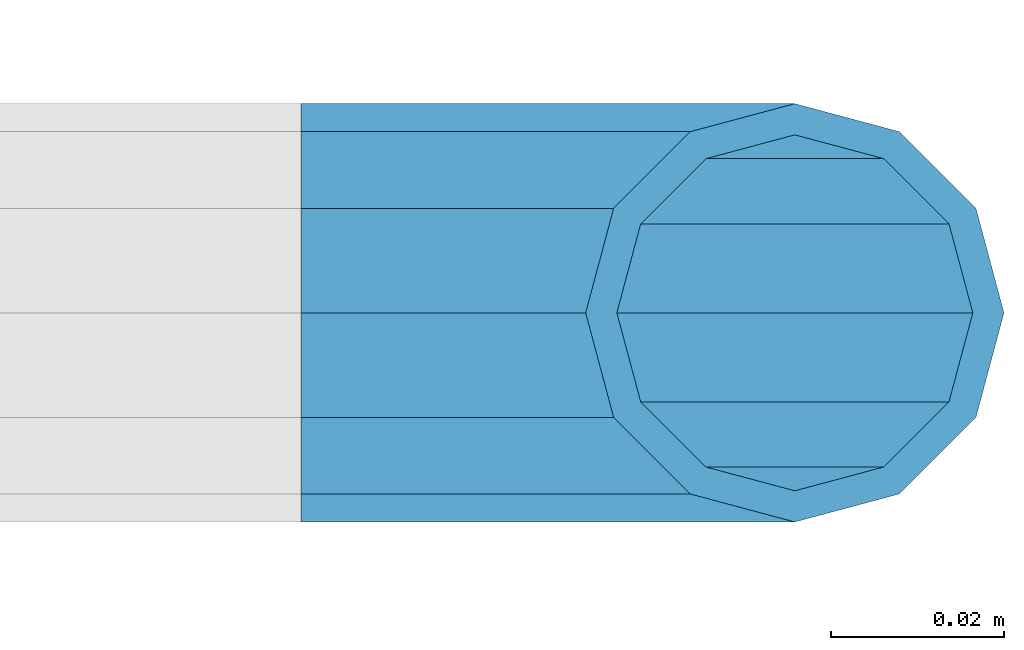
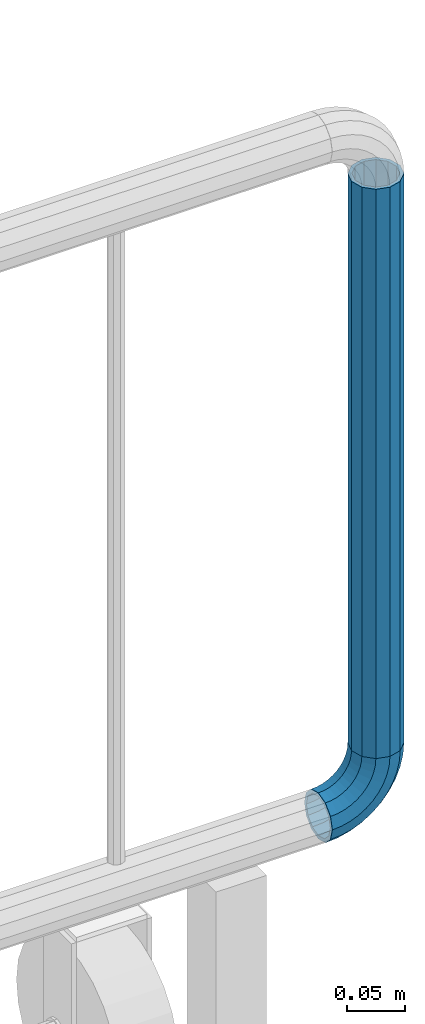
# One storey, part 171 of 240: 1 beam, 1 member.
"""IFC2X3 building model written with IfcOpenShell, lengths in millimetres."""

from ifc_helpers import new_model, si_unit, frame, origin_with_axes, place, context, subcontext, project, spatial, faceted_brep, material, type_object, element, save


model = new_model("IFC2X3")

# Units and contexts
model_context = context("Model", 3, precision=1e-05, world=origin_with_axes())
body_context = subcontext(model_context, "Body", "Model", "MODEL_VIEW")
ifc_project = project(units=[si_unit("LENGTHUNIT", "METRE", prefix="MILLI"), si_unit("AREAUNIT", "SQUARE_METRE"), si_unit("VOLUMEUNIT", "CUBIC_METRE"), si_unit("MASSUNIT", "GRAM", prefix="KILO"), si_unit("TIMEUNIT", "SECOND"), si_unit("PLANEANGLEUNIT", "RADIAN"), si_unit("SOLIDANGLEUNIT", "STERADIAN"), si_unit("THERMODYNAMICTEMPERATUREUNIT", "DEGREE_CELSIUS"), si_unit("LUMINOUSINTENSITYUNIT", "LUMEN")], contexts=[model_context])

# Site, building, storey
site_placement = place(None, origin_with_axes())
site = spatial("IfcSite", under=ifc_project, at=site_placement, CompositionType="ELEMENT")
building_placement = place(site_placement, origin_with_axes())
building = spatial("IfcBuilding", under=site, at=building_placement, Name="Standard", CompositionType="ELEMENT")
storey_placement = place(building_placement, origin_with_axes())
storey = spatial("IfcBuildingStorey", under=building, at=storey_placement, Name="Undefined", CompositionType="ELEMENT", Elevation=0.0)

# Member
ifc_material = material()
member_type = type_object("IfcMemberType", PredefinedType="NOTDEFINED")
member_placement = place(storey_placement, frame((69989.9460172356, 32941.8539999962, 281.650006544463), z_axis=(0.0, -1.0, 0.0), x_axis=(-0.707106781186548, 0.0, -0.707106781186548)))
element("IfcMember", 1, at=member_placement, inside=storey, type_object=member_type, material=ifc_material, context=body_context, shape_type="Brep", body=[
    faceted_brep([(17.0766287656515, -17.0766287656661, 0.0), (14.7887943220485, -14.788794322063, -12.0749999999971), (19.0945697419447, -11.1113146999778, -12.0749999999971), (20.9963409898191, -13.7288782624237, 0.0), (8.53831438282214, -8.53831438283669, -20.9145135013969), (13.8988340683864, -3.95999805534666, -20.9145135013969), (-7.27595761418343e-12, -7.27595761418343e-12, -24.1500000000015), (6.80132714695355, 5.80888215173036, -24.1500000000015), (-8.53831438283669, 8.53831438282214, -20.9145135013969), (-0.296179774479242, 15.5777623588074, -20.9145135013969), (-14.788794322063, 14.7887943220485, -12.0749999999971), (-5.49191544803034, 22.7290790034458, -12.0749999999971), (-17.0766287656588, 17.0766287656443, 0.0), (-7.39368669591204, 25.3466425658844, 0.0), (-14.788794322063, 14.7887943220485, 12.0749999999971), (-5.49191544803034, 22.7290790034458, 12.0749999999971), (-8.53831438283669, 8.53831438282214, 20.9145135013969), (-0.296179774479242, 15.5777623588074, 20.9145135013969), (-7.27595761418343e-12, -7.27595761418343e-12, 24.1500000000015), (6.80132714695355, 5.80888215173036, 24.1500000000015), (8.53831438282214, -8.53831438283669, 20.9145135013969), (13.8988340683864, -3.95999805534666, 20.9145135013969), (14.7887943220485, -14.788794322063, 12.0749999999971), (19.0945697419447, -11.1113146999778, 12.0749999999971), (14.5310443533745, -14.531044353389, 0.0), (12.5842535535412, -12.5842535535558, 10.2750000000015), (17.2620366843112, -8.58904933077429, 10.2750000000015), (18.8803140815653, -10.8164170826713, 0.0), (7.26552217668359, -7.26552217669814, 17.7968220477705), (12.8408206142631, -2.50376746547408, 17.7968220477705), (-7.27595761418343e-12, -7.27595761418343e-12, 20.5500000000029), (6.80132714695355, 5.80888215173036, 20.5500000000029), (-7.26552217669814, 7.26552217668359, 17.7968220477705), (0.761833679658594, 14.1215317689348, 17.7968220477705), (-12.5842535535558, 12.5842535535412, 10.2750000000015), (-3.65938239038951, 20.2068136342496, 10.2750000000015), (-14.531044353389, 14.5310443533745, 0.0), (-5.27765978765092, 22.4341813861392, 0.0), (-12.5842535535558, 12.5842535535412, -10.2750000000015), (-3.65938239038951, 20.2068136342496, -10.2750000000015), (-7.26552217669814, 7.26552217668359, -17.7968220477705), (0.761833679658594, 14.1215317689348, -17.7968220477705), (-7.27595761418343e-12, -7.27595761418343e-12, -20.5500000000029), (6.80132714695355, 5.80888215173036, -20.5500000000029), (7.26552217668359, -7.26552217669814, -17.7968220477705), (12.8408206142631, -2.50376746547408, -17.7968220477705), (12.5842535535412, -12.5842535535558, -10.2750000000015), (17.2620366843112, -8.58904933077429, -10.2750000000015), (23.922618478784, -8.15268262886093, -12.0749999999971), (25.3914986111849, -11.035522208047, 0.0), (19.9095633268225, -0.276618428477377, -20.9145135013969), (14.427628042482, 10.4822853510996, -24.1500000000015), (8.94569275811955, 21.2411891306692, -20.9145135013969), (4.93263760617265, 29.1172533310673, -12.0749999999971), (3.46375747377169, 32.0000929102534, 0.0), (4.93263760617265, 29.1172533310673, 12.0749999999971), (8.94569275811955, 21.2411891306692, 20.9145135013969), (14.427628042482, 10.4822853510996, 24.1500000000015), (19.9095633268225, -0.276618428477377, 20.9145135013969), (23.922618478784, -8.15268262886093, 12.0749999999971), (22.5072161777207, -5.37479920328769, 10.2750000000015), (23.7571328121194, -7.82789872097055, 0.0), (19.092380427297, 1.32719331506087, 17.7968220477705), (14.427628042482, 10.4822853510996, 20.5500000000029), (9.76287565764505, 19.637377387131, 17.7968220477705), (6.34803990724322, 26.3393699054868, 10.2750000000015), (5.09812327282998, 28.7924694231697, 0.0), (6.34803990724322, 26.3393699054868, -10.2750000000015), (9.76287565764505, 19.637377387131, -17.7968220477705), (14.427628042482, 10.4822853510996, -20.5500000000029), (19.092380427297, 1.32719331506087, -17.7968220477705), (22.5072161777207, -5.37479920328769, -10.2750000000015), (29.1540579492721, -5.98574944946449, -12.0749999999971), (30.153878262412, -9.06287996734318, 0.0), (26.4224980553408, 2.42112746692146, -20.9145135013969), (22.6911178482551, 13.9051349011861, -24.1500000000015), (18.9597376411839, 25.3891423354507, -20.9145135013969), (16.2281777472454, 33.7960192518294, -12.0749999999971), (15.2283574340981, 36.8731497697154, 0.0), (16.2281777472454, 33.7960192518294, 12.0749999999971), (18.9597376411839, 25.3891423354507, 20.9145135013969), (22.6911178482551, 13.9051349011861, 24.1500000000015), (26.4224980553408, 2.42112746692146, 20.9145135013969), (29.1540579492721, -5.98574944946449, 12.0749999999971), (28.1906383068854, -3.02064867669833, 10.2750000000015), (29.0414170826625, -5.63907650867623, 0.0), (25.8662674654624, 4.1330291962513, 17.7968220477705), (22.6911178482551, 13.9051349011861, 20.5500000000029), (19.515968231055, 23.6772406061136, 17.7968220477705), (17.1915973896321, 30.8309184790633, 10.2750000000015), (16.3408186138549, 33.4493463110557, 0.0), (17.1915973896321, 30.8309184790633, -10.2750000000015), (19.515968231055, 23.6772406061136, -17.7968220477705), (22.6911178482551, 13.9051349011861, -20.5500000000029), (25.8662674654624, 4.1330291962513, -17.7968220477705), (28.1906383068854, -3.02064867669833, -10.2750000000015), (34.6600727515033, -4.6638722482603, -12.0749999999971), (35.1662143510621, -7.85952453908976, 0.0), (33.277268185695, 4.06681217360165, -20.9145135013969), (31.3883220203425, 15.9931488862931, -24.1500000000015), (29.4993758549681, 27.9194855989626, -20.9145135013969), (28.116571289167, 36.6501700208319, -12.0749999999971), (27.6104296896156, 39.845822311654, 0.0), (28.116571289167, 36.6501700208319, 12.0749999999971), (29.4993758549681, 27.9194855989626, 20.9145135013969), (31.3883220203425, 15.9931488862931, 24.1500000000015), (33.277268185695, 4.06681217360165, 20.9145135013969), (34.6600727515033, -4.6638722482603, 12.0749999999971), (34.1723583567946, -1.58456474995182, 10.2750000000015), (34.6030502769136, -4.30384651295026, 0.0), (32.9956861486207, 5.8446511866714, 17.7968220477705), (31.3883220203425, 15.9931488862931, 20.5500000000029), (29.7809578920424, 26.1416465858929, 17.7968220477705), (28.6042856838831, 33.5708625225161, 10.2750000000015), (28.1735937637641, 36.2901442855145, 0.0), (28.6042856838831, 33.5708625225161, -10.2750000000015), (29.7809578920424, 26.1416465858929, -17.7968220477705), (31.3883220203425, 15.9931488862931, -20.5500000000029), (32.9956861486207, 5.8446511866714, -17.7968220477705), (34.1723583567946, -1.58456474995182, -10.2750000000015), (40.3050865276236, -4.21960002903506, -12.0749999999971), (40.3050865276236, -7.45508652764693, 0.0), (40.3050865276382, 4.61991347236471, -20.9145135013969), (40.3050865276236, 16.6949134723618, -24.1500000000015), (40.3050865276309, 28.7699134723662, -20.9145135013969), (40.3050865276309, 37.6094269737514, -12.0749999999971), (40.3050865276309, 40.8449134723633, 0.0), (40.3050865276309, 37.6094269737514, 12.0749999999971), (40.3050865276309, 28.7699134723662, 20.9145135013969), (40.3050865276236, 16.6949134723618, 24.1500000000015), (40.3050865276382, 4.61991347236471, 20.9145135013969), (40.3050865276236, -4.21960002903506, 12.0749999999971), (40.3050865276309, -1.10190857540874, 10.2750000000015), (40.3050865276309, -3.85508652763383, 0.0), (40.3050865276309, 6.41991347236035, 17.7968220477705), (40.3050865276236, 16.6949134723618, 20.5500000000029), (40.3050865276236, 26.969913472356, 17.7968220477705), (40.3050865276309, 34.4917355201324, 10.2750000000015), (40.3050865276309, 37.2449134723574, 0.0), (40.3050865276309, 34.4917355201324, -10.2750000000015), (40.3050865276236, 26.969913472356, -17.7968220477705), (40.3050865276236, 16.6949134723618, -20.5500000000029), (40.3050865276309, 6.41991347236035, -17.7968220477705), (40.3050865276309, -1.10190857540874, -10.2750000000015), (45.9501003037585, -4.6638722482603, -12.0749999999971), (45.443958704207, -7.85952453908249, 0.0), (47.3329048695668, 4.06681217360165, -20.9145135013969), (49.2218510349267, 15.9931488862858, -24.1500000000015), (51.1107972002865, 27.9194855989699, -20.9145135013969), (52.4936017660948, 36.6501700208319, -12.0749999999971), (52.9997433656463, 39.845822311654, 0.0), (52.4936017660948, 36.6501700208319, 12.0749999999971), (51.1107972002865, 27.9194855989699, 20.9145135013969), (49.2218510349267, 15.9931488862858, 24.1500000000015), (47.3329048695668, 4.06681217360165, 20.9145135013969), (45.9501003037585, -4.6638722482603, 12.0749999999971), (46.4378146984673, -1.58456474993727, 10.2750000000015), (46.007122778341, -4.30384651294298, 0.0), (47.6144869066411, 5.8446511866714, 17.7968220477705), (49.2218510349267, 15.9931488862858, 20.5500000000029), (50.8292151632122, 26.1416465859002, 17.7968220477705), (52.0058873713788, 33.5708625225161, 10.2750000000015), (52.4365792914905, 36.2901442855073, 0.0), (52.0058873713788, 33.5708625225161, -10.2750000000015), (50.8292151632122, 26.1416465859002, -17.7968220477705), (49.2218510349267, 15.9931488862858, -20.5500000000029), (47.6144869066411, 5.8446511866714, -17.7968220477705), (46.4378146984673, -1.58456474993727, -10.2750000000015), (51.4561151059825, -5.98574944945722, -12.0749999999971), (50.4562947928498, -9.06287996734318, 0.0), (54.187674999921, 2.42112746692146, -20.9145135013969), (57.9190552069995, 13.9051349011788, -24.1500000000015), (61.6504354140779, 25.3891423354507, -20.9145135013969), (64.3819953080165, 33.7960192518294, -12.0749999999971), (65.3818156211564, 36.8731497697081, 0.0), (64.3819953080165, 33.7960192518294, 12.0749999999971), (61.6504354140779, 25.3891423354507, 20.9145135013969), (57.9190552069995, 13.9051349011788, 24.1500000000015), (54.187674999921, 2.42112746692146, 20.9145135013969), (51.4561151059825, -5.98574944945722, 12.0749999999971), (52.4195347483765, -3.02064867668378, 10.2750000000015), (51.5687559725993, -5.63907650867623, 0.0), (54.7439055897994, 4.1330291962513, 17.7968220477705), (57.9190552069995, 13.9051349011788, 20.5500000000029), (61.0942048242068, 23.6772406061282, 17.7968220477705), (63.4185756656298, 30.8309184790633, 10.2750000000015), (64.2693544414069, 33.4493463110557, 0.0), (63.4185756656298, 30.8309184790633, -10.2750000000015), (61.0942048242068, 23.6772406061282, -17.7968220477705), (57.9190552069995, 13.9051349011788, -20.5500000000029), (54.7439055897994, 4.1330291962513, -17.7968220477705), (52.4195347483765, -3.02064867668378, -10.2750000000015), (56.6875545764706, -8.15268262886821, -12.0749999999971), (55.2186744440769, -11.035522208047, 0.0), (60.700609728432, -0.276618428470101, -20.9145135013969), (66.1825450127799, 10.4822853510996, -24.1500000000015), (71.6644802971277, 21.2411891306692, -20.9145135013969), (75.6775354490892, 29.1172533310673, -12.0749999999971), (77.1464155814901, 32.0000929102389, 0.0), (75.6775354490892, 29.1172533310673, 12.0749999999971), (71.6644802971277, 21.2411891306692, 20.9145135013969), (66.1825450127799, 10.4822853510996, 24.1500000000015), (60.700609728432, -0.276618428470101, 20.9145135013969), (56.6875545764706, -8.15268262886821, 12.0749999999971), (58.1029568775411, -5.37479920328769, 10.2750000000015), (56.8530402431425, -7.82789872097055, 0.0), (61.5177926279575, 1.32719331506814, 17.7968220477705), (66.1825450127799, 10.4822853510996, 20.5500000000029), (70.8472973976022, 19.637377387131, 17.7968220477705), (74.2621331480259, 26.3393699054795, 10.2750000000015), (75.5120497824319, 28.7924694231697, 0.0), (74.2621331480259, 26.3393699054795, -10.2750000000015), (70.8472973976022, 19.637377387131, -17.7968220477705), (66.1825450127799, 10.4822853510996, -20.5500000000029), (61.5177926279575, 1.32719331506814, -17.7968220477705), (58.1029568775411, -5.37479920328769, -10.2750000000015), (61.5156033133026, -11.1113146999778, -12.0749999999971), (59.6138320654354, -13.7288782624164, 0.0), (66.7113389868682, -3.95999805533938, -20.9145135013969), (73.808845908301, 5.80888215173763, -24.1500000000015), (80.9063528297338, 15.5777623588147, -20.9145135013969), (86.1020885032849, 22.7290790034385, -12.0749999999971), (88.0038597511593, 25.3466425658844, 0.0), (86.1020885032849, 22.7290790034385, 12.0749999999971), (80.9063528297338, 15.5777623588147, 20.9145135013969), (73.808845908301, 5.80888215173763, 24.1500000000015), (66.7113389868682, -3.95999805533938, 20.9145135013969), (61.5156033133026, -11.1113146999778, 12.0749999999971), (63.3481363709434, -8.58904933078156, 10.2750000000015), (61.7298589736965, -10.8164170826713, 0.0), (67.7693524409915, -2.50376746546681, 17.7968220477705), (73.808845908301, 5.80888215173763, 20.5500000000029), (79.8483393756032, 14.1215317689348, 17.7968220477705), (84.2695554456513, 20.2068136342496, 10.2750000000015), (85.8878328429128, 22.4341813861392, 0.0), (84.2695554456513, 20.2068136342496, -10.2750000000015), (79.8483393756032, 14.1215317689348, -17.7968220477705), (73.808845908301, 5.80888215173763, -20.5500000000029), (67.7693524409915, -2.50376746546681, -17.7968220477705), (63.3481363709434, -8.58904933078156, -10.2750000000015), (65.8213787332061, -14.7887943220558, -12.0749999999971), (63.5335442896103, -17.0766287656515, 0.0), (72.0718586724324, -8.53831438282941, -20.9145135013969), (80.6101730552618, 0.0, -24.1500000000015), (89.148487438084, 8.53831438282214, -20.9145135013969), (95.3989673773176, 14.7887943220558, -12.0749999999971), (97.6868018209134, 17.0766287656515, 0.0), (95.3989673773176, 14.7887943220558, 12.0749999999971), (89.148487438084, 8.53831438282214, 20.9145135013969), (80.6101730552618, 0.0, 24.1500000000015), (72.0718586724324, -8.53831438282941, 20.9145135013969), (65.8213787332061, -14.7887943220558, 12.0749999999971), (68.0259195017134, -12.5842535535485, 10.2750000000015), (66.0791287018728, -14.531044353389, 0.0), (73.344650878571, -7.26552217669087, 17.7968220477705), (80.6101730552618, 0.0, 20.5500000000029), (87.8756952319454, 7.26552217668359, 17.7968220477705), (93.194426608803, 12.5842535535412, 10.2750000000015), (95.1412174086436, 14.5310443533817, 0.0), (93.194426608803, 12.5842535535412, -10.2750000000015), (87.8756952319454, 7.26552217668359, -17.7968220477705), (80.6101730552618, 0.0, -20.5500000000029), (73.344650878571, -7.26552217669087, -17.7968220477705), (68.0259195017134, -12.5842535535485, -10.2750000000015)], [[[0, 1, 2, 3]], [[1, 4, 5, 2]], [[4, 6, 7, 5]], [[6, 8, 9, 7]], [[8, 10, 11, 9]], [[10, 12, 13, 11]], [[12, 14, 15, 13]], [[14, 16, 17, 15]], [[16, 18, 19, 17]], [[18, 20, 21, 19]], [[20, 22, 23, 21]], [[22, 0, 3, 23]], [[24, 25, 26, 27]], [[25, 28, 29, 26]], [[28, 30, 31, 29]], [[30, 32, 33, 31]], [[32, 34, 35, 33]], [[34, 36, 37, 35]], [[36, 38, 39, 37]], [[38, 40, 41, 39]], [[40, 42, 43, 41]], [[42, 44, 45, 43]], [[44, 46, 47, 45]], [[46, 24, 27, 47]], [[22, 20, 18, 16, 14, 12, 10, 8, 6, 4, 1, 0], [46, 44, 42, 40, 38, 36, 34, 32, 30, 28, 25, 24]], [[3, 2, 48, 49]], [[2, 5, 50, 48]], [[5, 7, 51, 50]], [[7, 9, 52, 51]], [[9, 11, 53, 52]], [[11, 13, 54, 53]], [[13, 15, 55, 54]], [[15, 17, 56, 55]], [[17, 19, 57, 56]], [[19, 21, 58, 57]], [[21, 23, 59, 58]], [[23, 3, 49, 59]], [[27, 26, 60, 61]], [[26, 29, 62, 60]], [[29, 31, 63, 62]], [[31, 33, 64, 63]], [[33, 35, 65, 64]], [[35, 37, 66, 65]], [[37, 39, 67, 66]], [[39, 41, 68, 67]], [[41, 43, 69, 68]], [[43, 45, 70, 69]], [[45, 47, 71, 70]], [[47, 27, 61, 71]], [[49, 48, 72, 73]], [[48, 50, 74, 72]], [[50, 51, 75, 74]], [[51, 52, 76, 75]], [[52, 53, 77, 76]], [[53, 54, 78, 77]], [[54, 55, 79, 78]], [[55, 56, 80, 79]], [[56, 57, 81, 80]], [[57, 58, 82, 81]], [[58, 59, 83, 82]], [[59, 49, 73, 83]], [[61, 60, 84, 85]], [[60, 62, 86, 84]], [[62, 63, 87, 86]], [[63, 64, 88, 87]], [[64, 65, 89, 88]], [[65, 66, 90, 89]], [[66, 67, 91, 90]], [[67, 68, 92, 91]], [[68, 69, 93, 92]], [[69, 70, 94, 93]], [[70, 71, 95, 94]], [[71, 61, 85, 95]], [[73, 72, 96, 97]], [[72, 74, 98, 96]], [[74, 75, 99, 98]], [[75, 76, 100, 99]], [[76, 77, 101, 100]], [[77, 78, 102, 101]], [[78, 79, 103, 102]], [[79, 80, 104, 103]], [[80, 81, 105, 104]], [[81, 82, 106, 105]], [[82, 83, 107, 106]], [[83, 73, 97, 107]], [[85, 84, 108, 109]], [[84, 86, 110, 108]], [[86, 87, 111, 110]], [[87, 88, 112, 111]], [[88, 89, 113, 112]], [[89, 90, 114, 113]], [[90, 91, 115, 114]], [[91, 92, 116, 115]], [[92, 93, 117, 116]], [[93, 94, 118, 117]], [[94, 95, 119, 118]], [[95, 85, 109, 119]], [[97, 96, 120, 121]], [[96, 98, 122, 120]], [[98, 99, 123, 122]], [[99, 100, 124, 123]], [[100, 101, 125, 124]], [[101, 102, 126, 125]], [[102, 103, 127, 126]], [[103, 104, 128, 127]], [[104, 105, 129, 128]], [[105, 106, 130, 129]], [[106, 107, 131, 130]], [[107, 97, 121, 131]], [[109, 108, 132, 133]], [[108, 110, 134, 132]], [[110, 111, 135, 134]], [[111, 112, 136, 135]], [[112, 113, 137, 136]], [[113, 114, 138, 137]], [[114, 115, 139, 138]], [[115, 116, 140, 139]], [[116, 117, 141, 140]], [[117, 118, 142, 141]], [[118, 119, 143, 142]], [[119, 109, 133, 143]], [[121, 120, 144, 145]], [[120, 122, 146, 144]], [[122, 123, 147, 146]], [[123, 124, 148, 147]], [[124, 125, 149, 148]], [[125, 126, 150, 149]], [[126, 127, 151, 150]], [[127, 128, 152, 151]], [[128, 129, 153, 152]], [[129, 130, 154, 153]], [[130, 131, 155, 154]], [[131, 121, 145, 155]], [[133, 132, 156, 157]], [[132, 134, 158, 156]], [[134, 135, 159, 158]], [[135, 136, 160, 159]], [[136, 137, 161, 160]], [[137, 138, 162, 161]], [[138, 139, 163, 162]], [[139, 140, 164, 163]], [[140, 141, 165, 164]], [[141, 142, 166, 165]], [[142, 143, 167, 166]], [[143, 133, 157, 167]], [[145, 144, 168, 169]], [[144, 146, 170, 168]], [[146, 147, 171, 170]], [[147, 148, 172, 171]], [[148, 149, 173, 172]], [[149, 150, 174, 173]], [[150, 151, 175, 174]], [[151, 152, 176, 175]], [[152, 153, 177, 176]], [[153, 154, 178, 177]], [[154, 155, 179, 178]], [[155, 145, 169, 179]], [[157, 156, 180, 181]], [[156, 158, 182, 180]], [[158, 159, 183, 182]], [[159, 160, 184, 183]], [[160, 161, 185, 184]], [[161, 162, 186, 185]], [[162, 163, 187, 186]], [[163, 164, 188, 187]], [[164, 165, 189, 188]], [[165, 166, 190, 189]], [[166, 167, 191, 190]], [[167, 157, 181, 191]], [[169, 168, 192, 193]], [[168, 170, 194, 192]], [[170, 171, 195, 194]], [[171, 172, 196, 195]], [[172, 173, 197, 196]], [[173, 174, 198, 197]], [[174, 175, 199, 198]], [[175, 176, 200, 199]], [[176, 177, 201, 200]], [[177, 178, 202, 201]], [[178, 179, 203, 202]], [[179, 169, 193, 203]], [[181, 180, 204, 205]], [[180, 182, 206, 204]], [[182, 183, 207, 206]], [[183, 184, 208, 207]], [[184, 185, 209, 208]], [[185, 186, 210, 209]], [[186, 187, 211, 210]], [[187, 188, 212, 211]], [[188, 189, 213, 212]], [[189, 190, 214, 213]], [[190, 191, 215, 214]], [[191, 181, 205, 215]], [[193, 192, 216, 217]], [[192, 194, 218, 216]], [[194, 195, 219, 218]], [[195, 196, 220, 219]], [[196, 197, 221, 220]], [[197, 198, 222, 221]], [[198, 199, 223, 222]], [[199, 200, 224, 223]], [[200, 201, 225, 224]], [[201, 202, 226, 225]], [[202, 203, 227, 226]], [[203, 193, 217, 227]], [[205, 204, 228, 229]], [[204, 206, 230, 228]], [[206, 207, 231, 230]], [[207, 208, 232, 231]], [[208, 209, 233, 232]], [[209, 210, 234, 233]], [[210, 211, 235, 234]], [[211, 212, 236, 235]], [[212, 213, 237, 236]], [[213, 214, 238, 237]], [[214, 215, 239, 238]], [[215, 205, 229, 239]], [[217, 216, 240, 241]], [[216, 218, 242, 240]], [[218, 219, 243, 242]], [[219, 220, 244, 243]], [[220, 221, 245, 244]], [[221, 222, 246, 245]], [[222, 223, 247, 246]], [[223, 224, 248, 247]], [[224, 225, 249, 248]], [[225, 226, 250, 249]], [[226, 227, 251, 250]], [[227, 217, 241, 251]], [[229, 228, 252, 253]], [[228, 230, 254, 252]], [[230, 231, 255, 254]], [[231, 232, 256, 255]], [[232, 233, 257, 256]], [[233, 234, 258, 257]], [[234, 235, 259, 258]], [[235, 236, 260, 259]], [[236, 237, 261, 260]], [[237, 238, 262, 261]], [[238, 239, 263, 262]], [[239, 229, 253, 263]], [[242, 243, 244, 245, 246, 247, 248, 249, 250, 251, 241, 240], [254, 255, 256, 257, 258, 259, 260, 261, 262, 263, 253, 252]]]),
])

# Beam
beam_type = type_object("IfcBeamType", PredefinedType="NOTDEFINED")
beam_placement = place(storey_placement, frame((69989.9460172356, 32941.8539999962, 878.350006544462), z_axis=(1.0, 0.0, 0.0), x_axis=(0.0, 0.0, -1.0)))
element("IfcBeam", 2, at=beam_placement, inside=storey, type_object=beam_type, material=ifc_material, context=body_context, shape_type="Brep", body=[
    faceted_brep([(0.0, -20.5500000000029, 0.0), (0.0, -17.7968220477705, 10.2749999999942), (596.700000000001, -17.7968220477705, 10.2749999999942), (596.700000000001, -20.5500000000029, 0.0), (0.0, -10.2750000000015, 17.7968220477633), (596.700000000001, -10.2750000000015, 17.7968220477633), (-7.27595761418343e-12, -7.27595761418343e-12, 20.5500000000029), (596.700000000001, 0.0, 20.5500000000029), (0.0, 10.2750000000015, 17.7968220477633), (596.700000000001, 10.2750000000015, 17.7968220477633), (0.0, 17.7968220477705, 10.2749999999942), (596.700000000001, 17.7968220477705, 10.2749999999942), (0.0, 20.5500000000029, 0.0), (596.700000000001, 20.5500000000029, 0.0), (0.0, 17.7968220477705, -10.2749999999942), (596.700000000001, 17.7968220477705, -10.2749999999942), (0.0, 10.2750000000015, -17.7968220477633), (596.700000000001, 10.2750000000015, -17.7968220477633), (-7.27595761418343e-12, -7.27595761418343e-12, -20.5500000000029), (596.700000000001, 0.0, -20.5500000000029), (0.0, -10.2750000000015, -17.7968220477633), (596.700000000001, -10.2750000000015, -17.7968220477633), (0.0, -17.7968220477705, -10.2749999999942), (596.700000000001, -17.7968220477705, -10.2749999999942), (0.0, -24.1500000000015, 0.0), (0.0, -20.9145135013969, -12.0749999999971), (596.700000000001, -20.9145135013969, -12.0749999999971), (596.700000000001, -24.1500000000015, 0.0), (0.0, -12.0749999999971, -20.9145135013969), (596.700000000001, -12.0749999999971, -20.9145135013969), (-7.27595761418343e-12, -7.27595761418343e-12, -24.1500000000015), (596.700000000001, 0.0, -24.1499999999942), (0.0, 12.0749999999971, -20.9145135013969), (596.700000000001, 12.0749999999971, -20.9145135013969), (0.0, 20.9145135013969, -12.0749999999971), (596.700000000001, 20.9145135013969, -12.0749999999971), (0.0, 24.1500000000015, 0.0), (596.700000000001, 24.1500000000015, 0.0), (0.0, 20.9145135013969, 12.0749999999971), (596.700000000001, 20.9145135013969, 12.0749999999971), (0.0, 12.0749999999971, 20.9145135013969), (596.700000000001, 12.0749999999971, 20.9145135013969), (-7.27595761418343e-12, -7.27595761418343e-12, 24.1500000000015), (596.700000000001, 0.0, 24.1499999999942), (0.0, -12.0749999999971, 20.9145135013969), (596.700000000001, -12.0749999999971, 20.9145135013969), (0.0, -20.9145135013969, 12.0749999999971), (596.700000000001, -20.9145135013969, 12.0749999999971)], [[[0, 1, 2, 3]], [[1, 4, 5, 2]], [[4, 6, 7, 5]], [[6, 8, 9, 7]], [[8, 10, 11, 9]], [[10, 12, 13, 11]], [[12, 14, 15, 13]], [[14, 16, 17, 15]], [[16, 18, 19, 17]], [[18, 20, 21, 19]], [[20, 22, 23, 21]], [[22, 0, 3, 23]], [[24, 25, 26, 27]], [[25, 28, 29, 26]], [[28, 30, 31, 29]], [[30, 32, 33, 31]], [[32, 34, 35, 33]], [[34, 36, 37, 35]], [[36, 38, 39, 37]], [[38, 40, 41, 39]], [[40, 42, 43, 41]], [[42, 44, 45, 43]], [[44, 46, 47, 45]], [[46, 24, 27, 47]], [[29, 31, 33, 35, 37, 39, 41, 43, 45, 47, 27, 26], [5, 7, 9, 11, 13, 15, 17, 19, 21, 23, 3, 2]], [[46, 44, 42, 40, 38, 36, 34, 32, 30, 28, 25, 24], [22, 20, 18, 16, 14, 12, 10, 8, 6, 4, 1, 0]]]),
])

save(model, "model.ifc")
